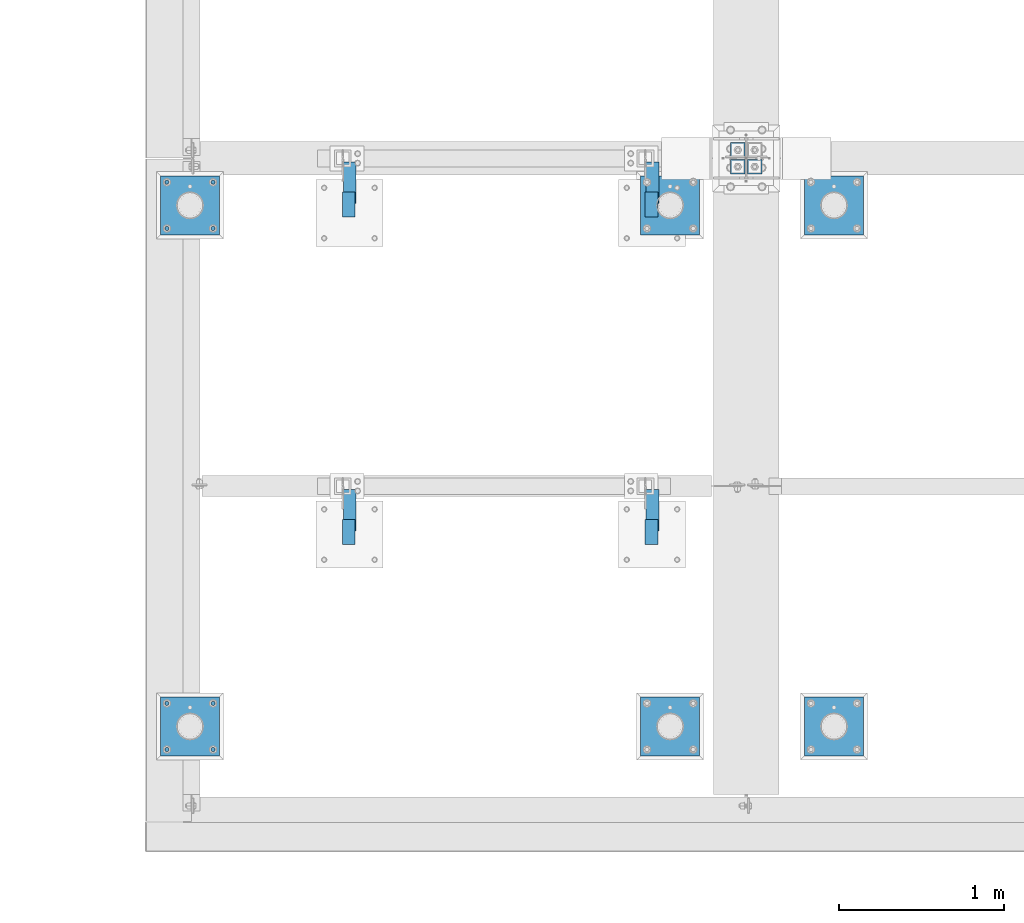
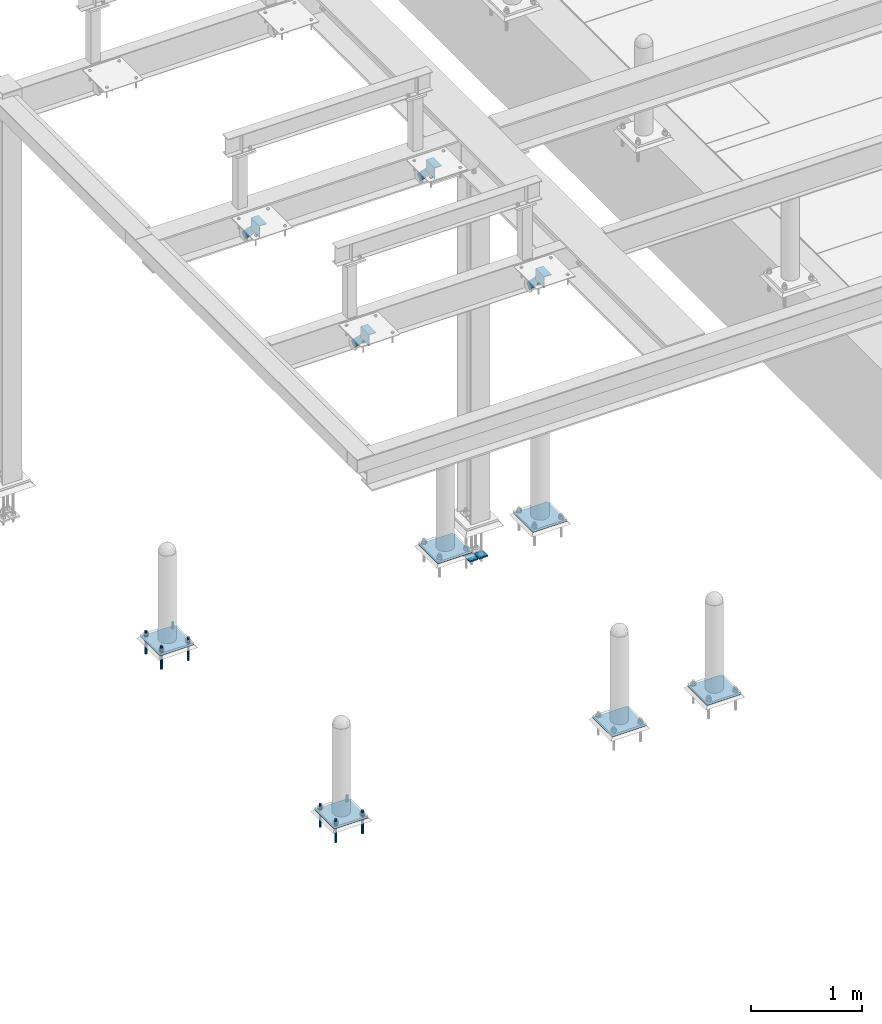
# One storey, part 2000 of 3843: 21 beams, 4 members, 15 elements without a shape of their own.
"""IFC2X3 building model written with IfcOpenShell, lengths in millimetres."""

from ifc_helpers import new_model, si_unit, frame, origin_with_axes, place, context, subcontext, project, spatial, faceted_brep, material, type_object, element, aggregate, save


model = new_model("IFC2X3")

# Units and contexts
model_context = context("Model", 3, precision=1e-05, world=origin_with_axes())
body_context = subcontext(model_context, "Body", "Model", "MODEL_VIEW")
ifc_project = project(units=[si_unit("LENGTHUNIT", "METRE", prefix="MILLI"), si_unit("AREAUNIT", "SQUARE_METRE"), si_unit("VOLUMEUNIT", "CUBIC_METRE"), si_unit("MASSUNIT", "GRAM", prefix="KILO"), si_unit("TIMEUNIT", "SECOND"), si_unit("PLANEANGLEUNIT", "RADIAN"), si_unit("SOLIDANGLEUNIT", "STERADIAN"), si_unit("THERMODYNAMICTEMPERATUREUNIT", "DEGREE_CELSIUS"), si_unit("LUMINOUSINTENSITYUNIT", "LUMEN")], contexts=[model_context])

# Site, building, storey
site_placement = place(None, origin_with_axes())
site = spatial("IfcSite", under=ifc_project, at=site_placement, CompositionType="ELEMENT")
building_placement = place(site_placement, origin_with_axes())
building = spatial("IfcBuilding", under=site, at=building_placement, Name="Undefined", CompositionType="ELEMENT")
storey_placement = place(building_placement, origin_with_axes())
storey = spatial("IfcBuildingStorey", under=building, at=storey_placement, Name="Undefined", CompositionType="ELEMENT", Elevation=0.0)

# Assembly, beams
assembly_1_placement = place(storey_placement, origin_with_axes())
assembly_1 = element("IfcElementAssembly", 1, at=assembly_1_placement, inside=storey, Name="TEMPLATE", AssemblyPlace="NOTDEFINED", PredefinedType="RIGID_FRAME")
ifc_material_1 = material(Name="STEEL/316 SS")
beam_type_1 = type_object("IfcBeamType", PredefinedType="NOTDEFINED")
beam_1_placement = place(assembly_1_placement, frame((33353.4207336426, 11425.6447954918, 30581.6), z_axis=(1.0, 0.0, 0.0), x_axis=(0.0, 0.0, -1.0)))
beam_1 = element("IfcBeam", 2, at=beam_1_placement, type_object=beam_type_1, material=ifc_material_1, Name="ANCHOR_ROD", context=body_context, shape_type="Brep", body=[
    faceted_brep([(0.0, -12.6999999999971, 0.0), (0.0, -10.9985226280696, -6.34999999999854), (253.999, -10.9985226280696, -6.34999999999854), (253.999, -12.6999999999971, 0.0), (0.0, -6.35000000000582, -10.9985226280623), (253.999, -6.35000000000582, -10.9985226280623), (0.0, 0.0, -12.6999999999971), (253.999, 0.0, -12.6999999999971), (0.0, 6.35000000000582, -10.9985226280623), (253.999, 6.35000000000582, -10.9985226280623), (0.0, 10.9985226280696, -6.34999999999854), (253.999, 10.9985226280696, -6.34999999999854), (0.0, 12.6999999999971, 0.0), (253.999, 12.6999999999971, 0.0), (0.0, 10.9985226280696, 6.34999999999854), (253.999, 10.9985226280696, 6.34999999999854), (0.0, 6.35000000000582, 10.9985226280623), (253.999, 6.35000000000582, 10.9985226280623), (0.0, 0.0, 12.6999999999971), (253.999, 0.0, 12.6999999999971), (0.0, -6.35000000000582, 10.9985226280623), (253.999, -6.35000000000582, 10.9985226280623), (0.0, -10.9985226280696, 6.34999999999854), (253.999, -10.9985226280696, 6.34999999999854)], [[[0, 1, 2, 3]], [[1, 4, 5, 2]], [[4, 6, 7, 5]], [[6, 8, 9, 7]], [[8, 10, 11, 9]], [[10, 12, 13, 11]], [[12, 14, 15, 13]], [[14, 16, 17, 15]], [[16, 18, 19, 17]], [[18, 20, 21, 19]], [[20, 22, 23, 21]], [[22, 0, 3, 23]], [[5, 7, 9, 11, 13, 15, 17, 19, 21, 23, 3, 2]], [[22, 20, 18, 16, 14, 12, 10, 8, 6, 4, 1, 0]]]),
])
beam_2_placement = place(assembly_1_placement, frame((33353.4207336426, 11705.0447954918, 30581.6), z_axis=(-1.0, 0.0, 0.0), x_axis=(0.0, 0.0, -1.0)))
beam_2 = element("IfcBeam", 3, at=beam_2_placement, type_object=beam_type_1, material=ifc_material_1, Name="ANCHOR_ROD", context=body_context, shape_type="Brep", body=[
    faceted_brep([(0.0, -12.6999999999971, 0.0), (0.0, -10.9985226280696, -6.34999999999854), (253.999, -10.9985226280696, -6.34999999999854), (253.999, -12.6999999999971, 0.0), (0.0, -6.35000000000582, -10.9985226280623), (253.999, -6.35000000000582, -10.9985226280623), (0.0, 0.0, -12.6999999999971), (253.999, 0.0, -12.6999999999971), (0.0, 6.35000000000582, -10.9985226280623), (253.999, 6.35000000000582, -10.9985226280623), (0.0, 10.9985226280696, -6.34999999999854), (253.999, 10.9985226280696, -6.34999999999854), (0.0, 12.6999999999971, 0.0), (253.999, 12.6999999999971, 0.0), (0.0, 10.9985226280696, 6.34999999999854), (253.999, 10.9985226280696, 6.34999999999854), (0.0, 6.35000000000582, 10.9985226280623), (253.999, 6.35000000000582, 10.9985226280623), (0.0, 0.0, 12.6999999999971), (253.999, 0.0, 12.6999999999971), (0.0, -6.35000000000582, 10.9985226280623), (253.999, -6.35000000000582, 10.9985226280623), (0.0, -10.9985226280696, 6.34999999999854), (253.999, -10.9985226280696, 6.34999999999854)], [[[0, 1, 2, 3]], [[1, 4, 5, 2]], [[4, 6, 7, 5]], [[6, 8, 9, 7]], [[8, 10, 11, 9]], [[10, 12, 13, 11]], [[12, 14, 15, 13]], [[14, 16, 17, 15]], [[16, 18, 19, 17]], [[18, 20, 21, 19]], [[20, 22, 23, 21]], [[22, 0, 3, 23]], [[5, 7, 9, 11, 13, 15, 17, 19, 21, 23, 3, 2]], [[22, 20, 18, 16, 14, 12, 10, 8, 6, 4, 1, 0]]]),
])
beam_3_placement = place(assembly_1_placement, frame((33074.0207336426, 11425.6447954918, 30581.6), z_axis=(1.0, 0.0, 0.0), x_axis=(0.0, 0.0, -1.0)))
beam_3 = element("IfcBeam", 4, at=beam_3_placement, type_object=beam_type_1, material=ifc_material_1, Name="ANCHOR_ROD", context=body_context, shape_type="Brep", body=[
    faceted_brep([(0.0, -12.6999999999971, 0.0), (0.0, -10.9985226280696, -6.34999999999854), (253.999, -10.9985226280696, -6.34999999999854), (253.999, -12.6999999999971, 0.0), (0.0, -6.35000000000582, -10.9985226280623), (253.999, -6.35000000000582, -10.9985226280623), (0.0, 0.0, -12.6999999999971), (253.999, 0.0, -12.6999999999971), (0.0, 6.35000000000582, -10.9985226280623), (253.999, 6.35000000000582, -10.9985226280623), (0.0, 10.9985226280696, -6.34999999999854), (253.999, 10.9985226280696, -6.34999999999854), (0.0, 12.6999999999971, 0.0), (253.999, 12.6999999999971, 0.0), (0.0, 10.9985226280696, 6.34999999999854), (253.999, 10.9985226280696, 6.34999999999854), (0.0, 6.35000000000582, 10.9985226280623), (253.999, 6.35000000000582, 10.9985226280623), (0.0, 0.0, 12.6999999999971), (253.999, 0.0, 12.6999999999971), (0.0, -6.35000000000582, 10.9985226280623), (253.999, -6.35000000000582, 10.9985226280623), (0.0, -10.9985226280696, 6.34999999999854), (253.999, -10.9985226280696, 6.34999999999854)], [[[0, 1, 2, 3]], [[1, 4, 5, 2]], [[4, 6, 7, 5]], [[6, 8, 9, 7]], [[8, 10, 11, 9]], [[10, 12, 13, 11]], [[12, 14, 15, 13]], [[14, 16, 17, 15]], [[16, 18, 19, 17]], [[18, 20, 21, 19]], [[20, 22, 23, 21]], [[22, 0, 3, 23]], [[5, 7, 9, 11, 13, 15, 17, 19, 21, 23, 3, 2]], [[22, 20, 18, 16, 14, 12, 10, 8, 6, 4, 1, 0]]]),
])
beam_4_placement = place(assembly_1_placement, frame((33074.0207336426, 11705.0447954918, 30581.6), z_axis=(-1.0, 0.0, 0.0), x_axis=(0.0, 0.0, -1.0)))
beam_4 = element("IfcBeam", 5, at=beam_4_placement, type_object=beam_type_1, material=ifc_material_1, Name="ANCHOR_ROD", context=body_context, shape_type="Brep", body=[
    faceted_brep([(0.0, -12.6999999999971, 0.0), (0.0, -10.9985226280696, -6.34999999999854), (253.999, -10.9985226280696, -6.34999999999854), (253.999, -12.6999999999971, 0.0), (0.0, -6.35000000000582, -10.9985226280623), (253.999, -6.35000000000582, -10.9985226280623), (0.0, 0.0, -12.6999999999971), (253.999, 0.0, -12.6999999999971), (0.0, 6.35000000000582, -10.9985226280623), (253.999, 6.35000000000582, -10.9985226280623), (0.0, 10.9985226280696, -6.34999999999854), (253.999, 10.9985226280696, -6.34999999999854), (0.0, 12.6999999999971, 0.0), (253.999, 12.6999999999971, 0.0), (0.0, 10.9985226280696, 6.34999999999854), (253.999, 10.9985226280696, 6.34999999999854), (0.0, 6.35000000000582, 10.9985226280623), (253.999, 6.35000000000582, 10.9985226280623), (0.0, 0.0, 12.6999999999971), (253.999, 0.0, 12.6999999999971), (0.0, -6.35000000000582, 10.9985226280623), (253.999, -6.35000000000582, 10.9985226280623), (0.0, -10.9985226280696, 6.34999999999854), (253.999, -10.9985226280696, 6.34999999999854)], [[[0, 1, 2, 3]], [[1, 4, 5, 2]], [[4, 6, 7, 5]], [[6, 8, 9, 7]], [[8, 10, 11, 9]], [[10, 12, 13, 11]], [[12, 14, 15, 13]], [[14, 16, 17, 15]], [[16, 18, 19, 17]], [[18, 20, 21, 19]], [[20, 22, 23, 21]], [[22, 0, 3, 23]], [[5, 7, 9, 11, 13, 15, 17, 19, 21, 23, 3, 2]], [[22, 20, 18, 16, 14, 12, 10, 8, 6, 4, 1, 0]]]),
])

assembly_2_placement = place(storey_placement, origin_with_axes())
assembly_2 = element("IfcElementAssembly", 6, at=assembly_2_placement, inside=storey, Name="TEMPLATE", AssemblyPlace="NOTDEFINED", PredefinedType="RIGID_FRAME")
beam_5_placement = place(assembly_2_placement, frame((33353.4207336426, 14575.2457781578, 30581.6), z_axis=(1.0, 0.0, 0.0), x_axis=(0.0, 0.0, -1.0)))
beam_5 = element("IfcBeam", 7, at=beam_5_placement, type_object=beam_type_1, material=ifc_material_1, Name="ANCHOR_ROD", context=body_context, shape_type="Brep", body=[
    faceted_brep([(0.0, -12.6999999999971, 0.0), (0.0, -10.9985226280696, -6.34999999999854), (253.999, -10.9985226280696, -6.34999999999854), (253.999, -12.6999999999971, 0.0), (0.0, -6.35000000000582, -10.9985226280623), (253.999, -6.35000000000582, -10.9985226280623), (0.0, 0.0, -12.6999999999971), (253.999, 0.0, -12.6999999999971), (0.0, 6.35000000000582, -10.9985226280623), (253.999, 6.35000000000582, -10.9985226280623), (0.0, 10.9985226280696, -6.34999999999854), (253.999, 10.9985226280696, -6.34999999999854), (0.0, 12.6999999999971, 0.0), (253.999, 12.6999999999971, 0.0), (0.0, 10.9985226280696, 6.34999999999854), (253.999, 10.9985226280696, 6.34999999999854), (0.0, 6.35000000000582, 10.9985226280623), (253.999, 6.35000000000582, 10.9985226280623), (0.0, 0.0, 12.6999999999971), (253.999, 0.0, 12.6999999999971), (0.0, -6.35000000000582, 10.9985226280623), (253.999, -6.35000000000582, 10.9985226280623), (0.0, -10.9985226280696, 6.34999999999854), (253.999, -10.9985226280696, 6.34999999999854)], [[[0, 1, 2, 3]], [[1, 4, 5, 2]], [[4, 6, 7, 5]], [[6, 8, 9, 7]], [[8, 10, 11, 9]], [[10, 12, 13, 11]], [[12, 14, 15, 13]], [[14, 16, 17, 15]], [[16, 18, 19, 17]], [[18, 20, 21, 19]], [[20, 22, 23, 21]], [[22, 0, 3, 23]], [[5, 7, 9, 11, 13, 15, 17, 19, 21, 23, 3, 2]], [[22, 20, 18, 16, 14, 12, 10, 8, 6, 4, 1, 0]]]),
])
beam_6_placement = place(assembly_2_placement, frame((33353.4207336426, 14854.6457781578, 30581.6), z_axis=(-1.0, 0.0, 0.0), x_axis=(0.0, 0.0, -1.0)))
beam_6 = element("IfcBeam", 8, at=beam_6_placement, type_object=beam_type_1, material=ifc_material_1, Name="ANCHOR_ROD", context=body_context, shape_type="Brep", body=[
    faceted_brep([(0.0, -12.6999999999971, 0.0), (0.0, -10.9985226280696, -6.34999999999854), (253.999, -10.9985226280696, -6.34999999999854), (253.999, -12.6999999999971, 0.0), (0.0, -6.35000000000582, -10.9985226280623), (253.999, -6.35000000000582, -10.9985226280623), (0.0, 0.0, -12.6999999999971), (253.999, 0.0, -12.6999999999971), (0.0, 6.35000000000582, -10.9985226280623), (253.999, 6.35000000000582, -10.9985226280623), (0.0, 10.9985226280696, -6.34999999999854), (253.999, 10.9985226280696, -6.34999999999854), (0.0, 12.6999999999971, 0.0), (253.999, 12.6999999999971, 0.0), (0.0, 10.9985226280696, 6.34999999999854), (253.999, 10.9985226280696, 6.34999999999854), (0.0, 6.35000000000582, 10.9985226280623), (253.999, 6.35000000000582, 10.9985226280623), (0.0, 0.0, 12.6999999999971), (253.999, 0.0, 12.6999999999971), (0.0, -6.35000000000582, 10.9985226280623), (253.999, -6.35000000000582, 10.9985226280623), (0.0, -10.9985226280696, 6.34999999999854), (253.999, -10.9985226280696, 6.34999999999854)], [[[0, 1, 2, 3]], [[1, 4, 5, 2]], [[4, 6, 7, 5]], [[6, 8, 9, 7]], [[8, 10, 11, 9]], [[10, 12, 13, 11]], [[12, 14, 15, 13]], [[14, 16, 17, 15]], [[16, 18, 19, 17]], [[18, 20, 21, 19]], [[20, 22, 23, 21]], [[22, 0, 3, 23]], [[5, 7, 9, 11, 13, 15, 17, 19, 21, 23, 3, 2]], [[22, 20, 18, 16, 14, 12, 10, 8, 6, 4, 1, 0]]]),
])
beam_7_placement = place(assembly_2_placement, frame((33074.0207336426, 14575.2457781578, 30581.6), z_axis=(1.0, 0.0, 0.0), x_axis=(0.0, 0.0, -1.0)))
beam_7 = element("IfcBeam", 9, at=beam_7_placement, type_object=beam_type_1, material=ifc_material_1, Name="ANCHOR_ROD", context=body_context, shape_type="Brep", body=[
    faceted_brep([(0.0, -12.6999999999971, 0.0), (0.0, -10.9985226280696, -6.34999999999854), (253.999, -10.9985226280696, -6.34999999999854), (253.999, -12.6999999999971, 0.0), (0.0, -6.35000000000582, -10.9985226280623), (253.999, -6.35000000000582, -10.9985226280623), (0.0, 0.0, -12.6999999999971), (253.999, 0.0, -12.6999999999971), (0.0, 6.35000000000582, -10.9985226280623), (253.999, 6.35000000000582, -10.9985226280623), (0.0, 10.9985226280696, -6.34999999999854), (253.999, 10.9985226280696, -6.34999999999854), (0.0, 12.6999999999971, 0.0), (253.999, 12.6999999999971, 0.0), (0.0, 10.9985226280696, 6.34999999999854), (253.999, 10.9985226280696, 6.34999999999854), (0.0, 6.35000000000582, 10.9985226280623), (253.999, 6.35000000000582, 10.9985226280623), (0.0, 0.0, 12.6999999999971), (253.999, 0.0, 12.6999999999971), (0.0, -6.35000000000582, 10.9985226280623), (253.999, -6.35000000000582, 10.9985226280623), (0.0, -10.9985226280696, 6.34999999999854), (253.999, -10.9985226280696, 6.34999999999854)], [[[0, 1, 2, 3]], [[1, 4, 5, 2]], [[4, 6, 7, 5]], [[6, 8, 9, 7]], [[8, 10, 11, 9]], [[10, 12, 13, 11]], [[12, 14, 15, 13]], [[14, 16, 17, 15]], [[16, 18, 19, 17]], [[18, 20, 21, 19]], [[20, 22, 23, 21]], [[22, 0, 3, 23]], [[5, 7, 9, 11, 13, 15, 17, 19, 21, 23, 3, 2]], [[22, 20, 18, 16, 14, 12, 10, 8, 6, 4, 1, 0]]]),
])
beam_8_placement = place(assembly_2_placement, frame((33074.0207336426, 14854.6457781578, 30581.6), z_axis=(-1.0, 0.0, 0.0), x_axis=(0.0, 0.0, -1.0)))
beam_8 = element("IfcBeam", 10, at=beam_8_placement, type_object=beam_type_1, material=ifc_material_1, Name="ANCHOR_ROD", context=body_context, shape_type="Brep", body=[
    faceted_brep([(0.0, -12.6999999999971, 0.0), (0.0, -10.9985226280696, -6.34999999999854), (253.999, -10.9985226280696, -6.34999999999854), (253.999, -12.6999999999971, 0.0), (0.0, -6.35000000000582, -10.9985226280623), (253.999, -6.35000000000582, -10.9985226280623), (0.0, 0.0, -12.6999999999971), (253.999, 0.0, -12.6999999999971), (0.0, 6.35000000000582, -10.9985226280623), (253.999, 6.35000000000582, -10.9985226280623), (0.0, 10.9985226280696, -6.34999999999854), (253.999, 10.9985226280696, -6.34999999999854), (0.0, 12.6999999999971, 0.0), (253.999, 12.6999999999971, 0.0), (0.0, 10.9985226280696, 6.34999999999854), (253.999, 10.9985226280696, 6.34999999999854), (0.0, 6.35000000000582, 10.9985226280623), (253.999, 6.35000000000582, 10.9985226280623), (0.0, 0.0, 12.6999999999971), (253.999, 0.0, 12.6999999999971), (0.0, -6.35000000000582, 10.9985226280623), (253.999, -6.35000000000582, 10.9985226280623), (0.0, -10.9985226280696, 6.34999999999854), (253.999, -10.9985226280696, 6.34999999999854)], [[[0, 1, 2, 3]], [[1, 4, 5, 2]], [[4, 6, 7, 5]], [[6, 8, 9, 7]], [[8, 10, 11, 9]], [[10, 12, 13, 11]], [[12, 14, 15, 13]], [[14, 16, 17, 15]], [[16, 18, 19, 17]], [[18, 20, 21, 19]], [[20, 22, 23, 21]], [[22, 0, 3, 23]], [[5, 7, 9, 11, 13, 15, 17, 19, 21, 23, 3, 2]], [[22, 20, 18, 16, 14, 12, 10, 8, 6, 4, 1, 0]]]),
])

# Beam
ifc_material_2 = material(Name="STEEL/A36")
beam_type_2 = type_object("IfcBeamType", PredefinedType="NOTDEFINED")
beam_9_placement = place(assembly_1_placement, frame((33391.5207336426, 11565.3447954918, 30506.9875), z_axis=(0.0, -1.0, 0.0), x_axis=(-1.0, 0.0, 0.0)))
beam_9 = element("IfcBeam", 11, at=beam_9_placement, type_object=beam_type_2, material=ifc_material_2, Name="TEMPLATE", context=body_context, shape_type="Brep", body=[
    faceted_brep([(0.0, 1.58750000000146, -177.800000000003), (0.0, 1.58750000000146, 177.800000000003), (355.600000000006, 1.58750000000146, 177.800000000003), (355.600000000006, 1.58750000000146, -177.800000000003), (0.0, -1.58750000000146, 177.800000000003), (355.600000000006, -1.58750000000146, 177.800000000003), (0.0, -1.58750000000146, -177.800000000003), (355.600000000006, -1.58750000000146, -177.800000000003)], [[[0, 1, 2, 3]], [[1, 4, 5, 2]], [[4, 6, 7, 5]], [[6, 0, 3, 7]], [[5, 7, 3, 2]], [[6, 4, 1, 0]]]),
])

aggregate(assembly_1, [beam_1, beam_2, beam_3, beam_4, beam_9])

beam_10_placement = place(assembly_2_placement, frame((33391.5207336426, 14714.9457781578, 30506.9875), z_axis=(0.0, -1.0, 0.0), x_axis=(-1.0, 0.0, 0.0)))
beam_10 = element("IfcBeam", 12, at=beam_10_placement, type_object=beam_type_2, material=ifc_material_2, Name="TEMPLATE", context=body_context, shape_type="Brep", body=[
    faceted_brep([(0.0, 1.58750000000146, -177.800000000003), (0.0, 1.58750000000146, 177.800000000003), (355.600000000006, 1.58750000000146, 177.800000000003), (355.600000000006, 1.58750000000146, -177.800000000003), (0.0, -1.58750000000146, 177.800000000003), (355.600000000006, -1.58750000000146, 177.800000000003), (0.0, -1.58750000000146, -177.800000000003), (355.600000000006, -1.58750000000146, -177.800000000003)], [[[0, 1, 2, 3]], [[1, 4, 5, 2]], [[4, 6, 7, 5]], [[6, 0, 3, 7]], [[5, 7, 3, 2]], [[6, 4, 1, 0]]]),
])

aggregate(assembly_2, [beam_5, beam_6, beam_7, beam_8, beam_10])

# Assembly, beam
assembly_3_placement = place(storey_placement, origin_with_axes())
assembly_3 = element("IfcElementAssembly", 13, at=assembly_3_placement, inside=storey, Name="TEMPLATE", AssemblyPlace="NOTDEFINED", PredefinedType="RIGID_FRAME")
beam_11_placement = place(assembly_3_placement, frame((36293.4715698242, 14714.9457781578, 30506.9875), z_axis=(0.0, -1.0, 0.0), x_axis=(-1.0, 0.0, 0.0)))
beam_11 = element("IfcBeam", 14, at=beam_11_placement, type_object=beam_type_2, material=ifc_material_2, Name="TEMPLATE", context=body_context, shape_type="Brep", body=[
    faceted_brep([(0.0, 1.58750000000146, -177.800000000003), (0.0, 1.58750000000146, 177.800000000003), (355.600000000006, 1.58750000000146, 177.800000000003), (355.600000000006, 1.58750000000146, -177.800000000003), (0.0, -1.58750000000146, 177.800000000003), (355.600000000006, -1.58750000000146, 177.800000000003), (0.0, -1.58750000000146, -177.800000000003), (355.600000000006, -1.58750000000146, -177.800000000003)], [[[0, 1, 2, 3]], [[1, 4, 5, 2]], [[4, 6, 7, 5]], [[6, 0, 3, 7]], [[5, 7, 3, 2]], [[6, 4, 1, 0]]]),
])
aggregate(assembly_3, [beam_11])

assembly_4_placement = place(storey_placement, origin_with_axes())
assembly_4 = element("IfcElementAssembly", 15, at=assembly_4_placement, inside=storey, Name="TEMPLATE", AssemblyPlace="NOTDEFINED", PredefinedType="RIGID_FRAME")
beam_12_placement = place(assembly_4_placement, frame((37284.0721557617, 14714.9457781578, 30506.9875), z_axis=(0.0, -1.0, 0.0), x_axis=(-1.0, 0.0, 0.0)))
beam_12 = element("IfcBeam", 16, at=beam_12_placement, type_object=beam_type_2, material=ifc_material_2, Name="TEMPLATE", context=body_context, shape_type="Brep", body=[
    faceted_brep([(0.0, 1.58750000000146, -177.800000000003), (0.0, 1.58750000000146, 177.800000000003), (355.600000000006, 1.58750000000146, 177.800000000003), (355.600000000006, 1.58750000000146, -177.800000000003), (0.0, -1.58750000000146, 177.800000000003), (355.600000000006, -1.58750000000146, 177.800000000003), (0.0, -1.58750000000146, -177.800000000003), (355.600000000006, -1.58750000000146, -177.800000000003)], [[[0, 1, 2, 3]], [[1, 4, 5, 2]], [[4, 6, 7, 5]], [[6, 0, 3, 7]], [[5, 7, 3, 2]], [[6, 4, 1, 0]]]),
])
aggregate(assembly_4, [beam_12])

assembly_5_placement = place(storey_placement, origin_with_axes())
assembly_5 = element("IfcElementAssembly", 17, at=assembly_5_placement, inside=storey, Name="TEMPLATE", AssemblyPlace="NOTDEFINED", PredefinedType="RIGID_FRAME")
beam_13_placement = place(assembly_5_placement, frame((37284.0721557617, 11565.3447954918, 30506.9875), z_axis=(0.0, -1.0, 0.0), x_axis=(-1.0, 0.0, 0.0)))
beam_13 = element("IfcBeam", 18, at=beam_13_placement, type_object=beam_type_2, material=ifc_material_2, Name="TEMPLATE", context=body_context, shape_type="Brep", body=[
    faceted_brep([(0.0, 1.58750000000146, -177.800000000003), (0.0, 1.58750000000146, 177.800000000003), (355.600000000006, 1.58750000000146, 177.800000000003), (355.600000000006, 1.58750000000146, -177.800000000003), (0.0, -1.58750000000146, 177.800000000003), (355.600000000006, -1.58750000000146, 177.800000000003), (0.0, -1.58750000000146, -177.800000000003), (355.600000000006, -1.58750000000146, -177.800000000003)], [[[0, 1, 2, 3]], [[1, 4, 5, 2]], [[4, 6, 7, 5]], [[6, 0, 3, 7]], [[5, 7, 3, 2]], [[6, 4, 1, 0]]]),
])
aggregate(assembly_5, [beam_13])

assembly_6_placement = place(storey_placement, origin_with_axes())
assembly_6 = element("IfcElementAssembly", 19, at=assembly_6_placement, inside=storey, Name="TEMPLATE", AssemblyPlace="NOTDEFINED", PredefinedType="RIGID_FRAME")
beam_14_placement = place(assembly_6_placement, frame((36293.4715698242, 11565.3447954918, 30506.9875), z_axis=(0.0, -1.0, 0.0), x_axis=(-1.0, 0.0, 0.0)))
beam_14 = element("IfcBeam", 20, at=beam_14_placement, type_object=beam_type_2, material=ifc_material_2, Name="TEMPLATE", context=body_context, shape_type="Brep", body=[
    faceted_brep([(0.0, 1.58750000000146, -177.800000000003), (0.0, 1.58750000000146, 177.800000000003), (355.600000000006, 1.58750000000146, 177.800000000003), (355.600000000006, 1.58750000000146, -177.800000000003), (0.0, -1.58750000000146, 177.800000000003), (355.600000000006, -1.58750000000146, 177.800000000003), (0.0, -1.58750000000146, -177.800000000003), (355.600000000006, -1.58750000000146, -177.800000000003)], [[[0, 1, 2, 3]], [[1, 4, 5, 2]], [[4, 6, 7, 5]], [[6, 0, 3, 7]], [[5, 7, 3, 2]], [[6, 4, 1, 0]]]),
])
aggregate(assembly_6, [beam_14])

assembly_7_placement = place(storey_placement, origin_with_axes())
assembly_7 = element("IfcElementAssembly", 21, at=assembly_7_placement, inside=storey, Name="ANGLE", AssemblyPlace="NOTDEFINED", PredefinedType="RIGID_FRAME")
ifc_material_3 = material(Name="STEEL/A572-50")
beam_type_3 = type_object("IfcBeamType", Name="L5X3X1/4", PredefinedType="NOTDEFINED")
beam_15_placement = place(assembly_7_placement, frame((34174.1125, 12817.3815367162, 34737.675), z_axis=(0.0, 0.0, -1.0), x_axis=(0.0, -1.0, 0.0)))
beam_15 = element("IfcBeam", 22, at=beam_15_placement, type_object=beam_type_3, material=ifc_material_3, Name="ANGLE", ObjectType="L5X3X1/4", context=body_context, shape_type="Brep", body=[
    faceted_brep([(0.0, 38.0999999999985, -63.5), (0.0, 38.0999999999985, 63.5), (152.400000000001, 38.0999999999985, 63.5), (152.399999999994, 38.0999999999985, -63.5), (0.0, 31.75, 63.5), (152.400000000001, 31.75, 63.5), (0.0, 31.75, -57.1500000000015), (152.400000000001, 31.75, -57.1500000000015), (0.0, -38.0999999999985, -57.1500000000015), (152.400000000001, -38.0999999999985, -57.1500000000015), (0.0, -38.0999999999985, -63.5), (152.400000000001, -38.0999999999985, -63.5)], [[[0, 1, 2, 3]], [[1, 4, 5, 2]], [[4, 6, 7, 5]], [[6, 8, 9, 7]], [[8, 10, 11, 9]], [[10, 0, 3, 11]], [[5, 7, 9, 11, 3, 2]], [[10, 8, 6, 4, 1, 0]]]),
])
aggregate(assembly_7, [beam_15])

assembly_8_placement = place(storey_placement, origin_with_axes())
assembly_8 = element("IfcElementAssembly", 23, at=assembly_8_placement, inside=storey, Name="ANGLE", AssemblyPlace="NOTDEFINED", PredefinedType="RIGID_FRAME")
beam_16_placement = place(assembly_8_placement, frame((36002.9125, 12817.3815367162, 34737.675), z_axis=(0.0, 0.0, -1.0), x_axis=(0.0, -1.0, 0.0)))
beam_16 = element("IfcBeam", 24, at=beam_16_placement, type_object=beam_type_3, material=ifc_material_3, Name="ANGLE", ObjectType="L5X3X1/4", context=body_context, shape_type="Brep", body=[
    faceted_brep([(0.0, 38.0999999999985, -63.5), (0.0, 38.0999999999985, 63.5), (152.400000000001, 38.0999999999985, 63.5), (152.399999999994, 38.0999999999985, -63.5), (0.0, 31.75, 63.5), (152.400000000001, 31.75, 63.5), (0.0, 31.75, -57.1500000000015), (152.400000000001, 31.75, -57.1500000000015), (0.0, -38.0999999999985, -57.1500000000015), (152.400000000001, -38.0999999999985, -57.1500000000015), (0.0, -38.0999999999985, -63.5), (152.400000000001, -38.0999999999985, -63.5)], [[[0, 1, 2, 3]], [[1, 4, 5, 2]], [[4, 6, 7, 5]], [[6, 8, 9, 7]], [[8, 10, 11, 9]], [[10, 0, 3, 11]], [[5, 7, 9, 11, 3, 2]], [[10, 8, 6, 4, 1, 0]]]),
])
aggregate(assembly_8, [beam_16])

assembly_9_placement = place(storey_placement, origin_with_axes())
assembly_9 = element("IfcElementAssembly", 25, at=assembly_9_placement, inside=storey, Name="ANGLE", AssemblyPlace="NOTDEFINED", PredefinedType="RIGID_FRAME")
beam_17_placement = place(assembly_9_placement, frame((34174.1125, 14796.9940367162, 34737.675), z_axis=(0.0, 0.0, -1.0), x_axis=(0.0, -1.0, 0.0)))
beam_17 = element("IfcBeam", 26, at=beam_17_placement, type_object=beam_type_3, material=ifc_material_3, Name="ANGLE", ObjectType="L5X3X1/4", context=body_context, shape_type="Brep", body=[
    faceted_brep([(0.0, 38.0999999999985, -63.5), (0.0, 38.0999999999985, 63.5), (152.400000000001, 38.0999999999985, 63.5), (152.399999999994, 38.0999999999985, -63.5), (0.0, 31.75, 63.5), (152.400000000001, 31.75, 63.5), (0.0, 31.75, -57.1500000000015), (152.400000000001, 31.75, -57.1500000000015), (0.0, -38.0999999999985, -57.1500000000015), (152.400000000001, -38.0999999999985, -57.1500000000015), (0.0, -38.0999999999985, -63.5), (152.400000000001, -38.0999999999985, -63.5)], [[[0, 1, 2, 3]], [[1, 4, 5, 2]], [[4, 6, 7, 5]], [[6, 8, 9, 7]], [[8, 10, 11, 9]], [[10, 0, 3, 11]], [[5, 7, 9, 11, 3, 2]], [[10, 8, 6, 4, 1, 0]]]),
])
aggregate(assembly_9, [beam_17])

assembly_10_placement = place(storey_placement, origin_with_axes())
assembly_10 = element("IfcElementAssembly", 27, at=assembly_10_placement, inside=storey, Name="ANGLE", AssemblyPlace="NOTDEFINED", PredefinedType="RIGID_FRAME")
beam_18_placement = place(assembly_10_placement, frame((36002.9125, 14796.9940367162, 34737.675), z_axis=(0.0, 0.0, -1.0), x_axis=(0.0, -1.0, 0.0)))
beam_18 = element("IfcBeam", 28, at=beam_18_placement, type_object=beam_type_3, material=ifc_material_3, Name="ANGLE", ObjectType="L5X3X1/4", context=body_context, shape_type="Brep", body=[
    faceted_brep([(0.0, 38.0999999999985, -63.5), (0.0, 38.0999999999985, 63.5), (152.400000000001, 38.0999999999985, 63.5), (152.399999999994, 38.0999999999985, -63.5), (0.0, 31.75, 63.5), (152.400000000001, 31.75, 63.5), (0.0, 31.75, -57.1500000000015), (152.400000000001, 31.75, -57.1500000000015), (0.0, -38.0999999999985, -57.1500000000015), (152.400000000001, -38.0999999999985, -57.1500000000015), (0.0, -38.0999999999985, -63.5), (152.400000000001, -38.0999999999985, -63.5)], [[[0, 1, 2, 3]], [[1, 4, 5, 2]], [[4, 6, 7, 5]], [[6, 8, 9, 7]], [[8, 10, 11, 9]], [[10, 0, 3, 11]], [[5, 7, 9, 11, 3, 2]], [[10, 8, 6, 4, 1, 0]]]),
])
aggregate(assembly_10, [beam_18])

# Assembly, member
assembly_11_placement = place(storey_placement, origin_with_axes())
assembly_11 = element("IfcElementAssembly", 29, at=assembly_11_placement, inside=storey, Name="ANGLE", AssemblyPlace="NOTDEFINED", PredefinedType="RIGID_FRAME")
member_type = type_object("IfcMemberType", Name="L3X3X1/4", PredefinedType="NOTDEFINED")
member_1_placement = place(assembly_11_placement, frame((34180.4625, 12677.230256111, 34801.7197438789), z_axis=(1.0, 0.0, 0.0), x_axis=(5.70000238222118e-08, 0.707106781186546, -0.707106781186546)))
member_1 = element("IfcMember", 30, at=member_1_placement, type_object=member_type, material=ifc_material_3, Name="ANGLE", ObjectType="L3X3X1/4", context=body_context, shape_type="Brep", body=[
    faceted_brep([(65.0407683629346, 38.1000000000349, -38.0999999999985), (65.0407683629346, 38.1000000000349, 38.0999999999985), (415.402934126978, 38.1000000004933, 38.0999999999985), (415.402934126978, 38.1000000004933, -38.0999999999985), (65.0407683629219, 31.7500000000509, 38.0999999999985), (415.402934126972, 31.7500000004948, 38.0999999999985), (65.0407683629219, 31.7500000000509, -31.75), (415.402934126972, 31.7500000004948, -31.75), (65.0407683628364, -38.0999999998749, -31.75), (415.402934126882, -38.099999999431, -31.75), (65.0407683628364, -38.0999999998749, -38.0999999999985), (415.402934126882, -38.099999999431, -38.0999999999985)], [[[0, 1, 2, 3]], [[1, 4, 5, 2]], [[4, 6, 7, 5]], [[6, 8, 9, 7]], [[8, 10, 11, 9]], [[10, 0, 3, 11]], [[5, 7, 9, 11, 3, 2]], [[10, 8, 6, 4, 1, 0]]]),
])
aggregate(assembly_11, [member_1])

assembly_12_placement = place(storey_placement, origin_with_axes())
assembly_12 = element("IfcElementAssembly", 31, at=assembly_12_placement, inside=storey, Name="ANGLE", AssemblyPlace="NOTDEFINED", PredefinedType="RIGID_FRAME")
member_2_placement = place(assembly_12_placement, frame((36009.2625, 12677.230256111, 34801.7197438789), z_axis=(1.0, 0.0, 0.0), x_axis=(5.70000238222118e-08, 0.707106781186546, -0.707106781186546)))
member_2 = element("IfcMember", 32, at=member_2_placement, type_object=member_type, material=ifc_material_3, Name="ANGLE", ObjectType="L3X3X1/4", context=body_context, shape_type="Brep", body=[
    faceted_brep([(65.0407683629346, 38.1000000000349, -38.0999999999985), (65.0407683629346, 38.1000000000349, 38.0999999999985), (415.402934126978, 38.1000000004933, 38.0999999999985), (415.402934126978, 38.1000000004933, -38.0999999999985), (65.0407683629219, 31.7500000000509, 38.0999999999985), (415.402934126972, 31.7500000004948, 38.0999999999985), (65.0407683629219, 31.7500000000509, -31.75), (415.402934126972, 31.7500000004948, -31.75), (65.0407683628364, -38.0999999998749, -31.75), (415.402934126882, -38.099999999431, -31.75), (65.0407683628364, -38.0999999998749, -38.0999999999985), (415.402934126882, -38.099999999431, -38.0999999999985)], [[[0, 1, 2, 3]], [[1, 4, 5, 2]], [[4, 6, 7, 5]], [[6, 8, 9, 7]], [[8, 10, 11, 9]], [[10, 0, 3, 11]], [[5, 7, 9, 11, 3, 2]], [[10, 8, 6, 4, 1, 0]]]),
])
aggregate(assembly_12, [member_2])

assembly_13_placement = place(storey_placement, origin_with_axes())
assembly_13 = element("IfcElementAssembly", 33, at=assembly_13_placement, inside=storey, Name="ANGLE", AssemblyPlace="NOTDEFINED", PredefinedType="RIGID_FRAME")
member_3_placement = place(assembly_13_placement, frame((34180.4625, 14656.8427561109, 34800.1322438789), z_axis=(1.0, 0.0, 0.0), x_axis=(5.70000238222118e-08, 0.707106781186546, -0.707106781186546)))
member_3 = element("IfcMember", 34, at=member_3_placement, type_object=member_type, material=ifc_material_3, Name="ANGLE", ObjectType="L3X3X1/4", context=body_context, shape_type="Brep", body=[
    faceted_brep([(65.0407683629346, 38.1000000000349, -38.0999999999985), (65.0407683629346, 38.1000000000349, 38.0999999999985), (415.402934126978, 38.1000000004933, 38.0999999999985), (415.402934126978, 38.1000000004933, -38.0999999999985), (65.0407683629219, 31.7500000000509, 38.0999999999985), (415.402934126972, 31.7500000004948, 38.0999999999985), (65.0407683629219, 31.7500000000509, -31.75), (415.402934126972, 31.7500000004948, -31.75), (65.0407683628364, -38.0999999998749, -31.75), (415.402934126882, -38.099999999431, -31.75), (65.0407683628364, -38.0999999998749, -38.0999999999985), (415.402934126882, -38.099999999431, -38.0999999999985)], [[[0, 1, 2, 3]], [[1, 4, 5, 2]], [[4, 6, 7, 5]], [[6, 8, 9, 7]], [[8, 10, 11, 9]], [[10, 0, 3, 11]], [[5, 7, 9, 11, 3, 2]], [[10, 8, 6, 4, 1, 0]]]),
])
aggregate(assembly_13, [member_3])

assembly_14_placement = place(storey_placement, origin_with_axes())
assembly_14 = element("IfcElementAssembly", 35, at=assembly_14_placement, inside=storey, Name="ANGLE", AssemblyPlace="NOTDEFINED", PredefinedType="RIGID_FRAME")
member_4_placement = place(assembly_14_placement, frame((36009.2625, 14656.8427561109, 34800.1322438789), z_axis=(1.0, 0.0, 0.0), x_axis=(5.70000238222118e-08, 0.707106781186546, -0.707106781186546)))
member_4 = element("IfcMember", 36, at=member_4_placement, type_object=member_type, material=ifc_material_3, Name="ANGLE", ObjectType="L3X3X1/4", context=body_context, shape_type="Brep", body=[
    faceted_brep([(65.0407683629346, 38.1000000000349, -38.0999999999985), (65.0407683629346, 38.1000000000349, 38.0999999999985), (415.402934126978, 38.1000000004933, 38.0999999999985), (415.402934126978, 38.1000000004933, -38.0999999999985), (65.0407683629219, 31.7500000000509, 38.0999999999985), (415.402934126972, 31.7500000004948, 38.0999999999985), (65.0407683629219, 31.7500000000509, -31.75), (415.402934126972, 31.7500000004948, -31.75), (65.0407683628364, -38.0999999998749, -31.75), (415.402934126882, -38.099999999431, -31.75), (65.0407683628364, -38.0999999998749, -38.0999999999985), (415.402934126882, -38.099999999431, -38.0999999999985)], [[[0, 1, 2, 3]], [[1, 4, 5, 2]], [[4, 6, 7, 5]], [[6, 8, 9, 7]], [[8, 10, 11, 9]], [[10, 0, 3, 11]], [[5, 7, 9, 11, 3, 2]], [[10, 8, 6, 4, 1, 0]]]),
])
aggregate(assembly_14, [member_4])

# Assembly, beams
assembly_15_placement = place(storey_placement, origin_with_axes())
assembly_15 = element("IfcElementAssembly", 37, at=assembly_15_placement, inside=storey, Name="TEMPLATE", AssemblyPlace="NOTDEFINED", PredefinedType="RIGID_FRAME")
beam_type_4 = type_object("IfcBeamType", PredefinedType="NOTDEFINED")
beam_19_placement = place(assembly_15_placement, frame((36525.2, 14903.45, 30116.4625), z_axis=(1.0, 0.0, 0.0), x_axis=(0.0, 1.0, 0.0)))
beam_19 = element("IfcBeam", 38, at=beam_19_placement, type_object=beam_type_4, material=ifc_material_3, context=body_context, shape_type="Brep", body=[
    faceted_brep([(0.0, 7.9375, -44.4499999999971), (0.0, 7.9375, 44.4499999999971), (88.8999999999942, 7.9375, 44.4499999999971), (88.8999999999942, 7.9375, -44.4499999999971), (0.0, -7.9375, 44.4499999999971), (88.8999999999942, -7.9375, 44.4499999999971), (0.0, -7.9375, -44.4499999999971), (88.8999999999942, -7.9375, -44.4499999999971)], [[[0, 1, 2, 3]], [[1, 4, 5, 2]], [[4, 6, 7, 5]], [[6, 0, 3, 7]], [[5, 7, 3, 2]], [[6, 4, 1, 0]]]),
])
beam_20_placement = place(assembly_15_placement, frame((36626.8, 14903.45, 30116.4625), z_axis=(1.0, 0.0, 0.0), x_axis=(0.0, 1.0, 0.0)))
beam_20 = element("IfcBeam", 39, at=beam_20_placement, type_object=beam_type_4, material=ifc_material_3, context=body_context, shape_type="Brep", body=[
    faceted_brep([(0.0, 7.9375, -44.4499999999971), (0.0, 7.9375, 44.4499999999971), (88.8999999999942, 7.9375, 44.4499999999971), (88.8999999999942, 7.9375, -44.4499999999971), (0.0, -7.9375, 44.4499999999971), (88.8999999999942, -7.9375, 44.4499999999971), (0.0, -7.9375, -44.4499999999971), (88.8999999999942, -7.9375, -44.4499999999971)], [[[0, 1, 2, 3]], [[1, 4, 5, 2]], [[4, 6, 7, 5]], [[6, 0, 3, 7]], [[5, 7, 3, 2]], [[6, 4, 1, 0]]]),
])
beam_21_placement = place(assembly_15_placement, frame((36525.2, 15005.05, 30116.4625), z_axis=(1.0, 0.0, 0.0), x_axis=(0.0, 1.0, 0.0)))
beam_21 = element("IfcBeam", 40, at=beam_21_placement, type_object=beam_type_4, material=ifc_material_3, context=body_context, shape_type="Brep", body=[
    faceted_brep([(0.0, 7.9375, -44.4499999999971), (0.0, 7.9375, 44.4499999999971), (88.8999999999942, 7.9375, 44.4499999999971), (88.8999999999942, 7.9375, -44.4499999999971), (0.0, -7.9375, 44.4499999999971), (88.8999999999942, -7.9375, 44.4499999999971), (0.0, -7.9375, -44.4499999999971), (88.8999999999942, -7.9375, -44.4499999999971)], [[[0, 1, 2, 3]], [[1, 4, 5, 2]], [[4, 6, 7, 5]], [[6, 0, 3, 7]], [[5, 7, 3, 2]], [[6, 4, 1, 0]]]),
])
aggregate(assembly_15, [beam_19, beam_20, beam_21])

save(model, "model.ifc")
